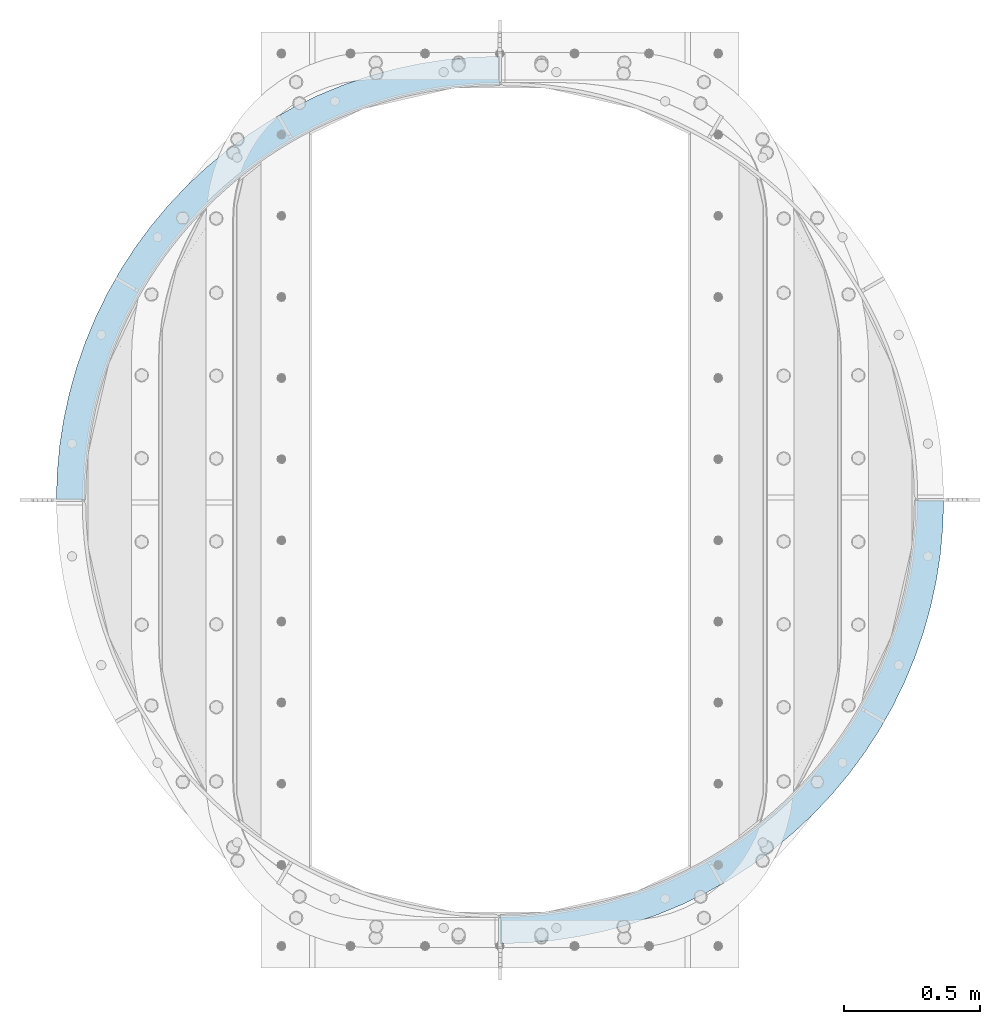
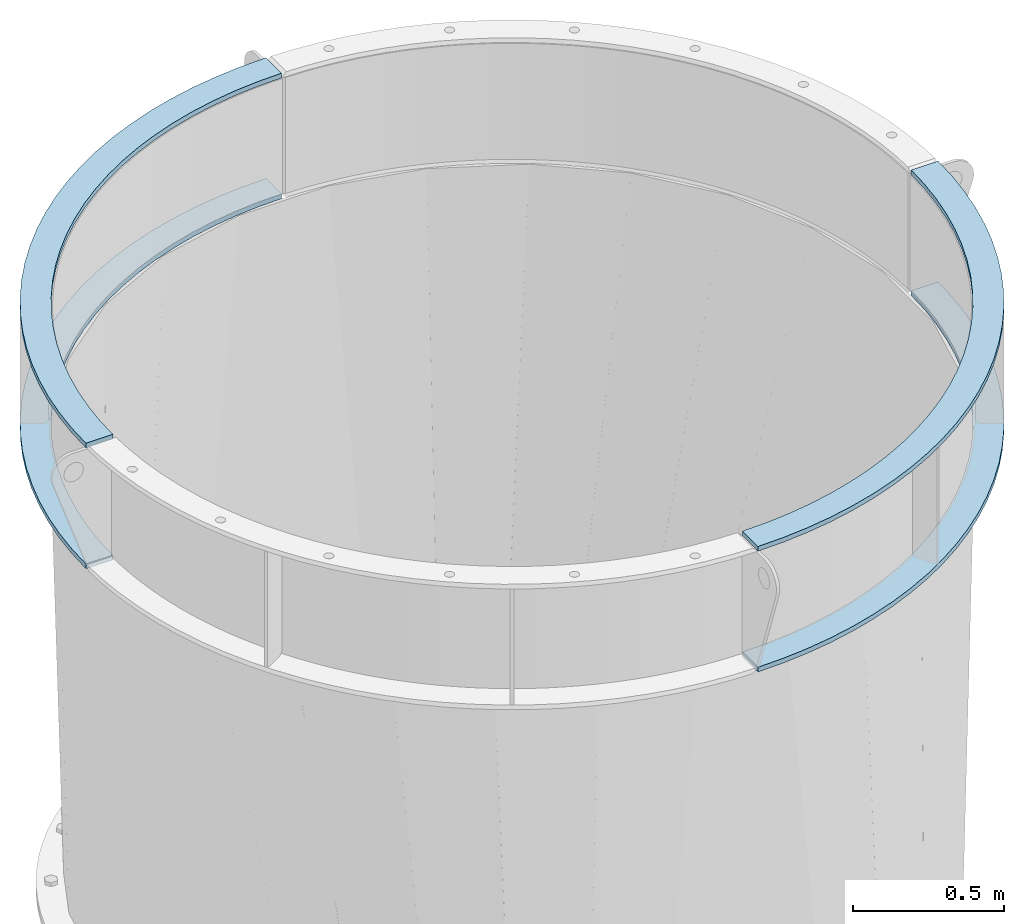
# One storey, part 12 of 15: 4 plates, 1 element without a shape of its own.
"""IFC2X3 building model written with IfcOpenShell, lengths in millimetres."""

from ifc_helpers import new_model, si_unit, frame, origin_with_axes, place, context, subcontext, project, spatial, faceted_brep, material, type_object, element, aggregate, save


model = new_model("IFC2X3")

# Units and contexts
model_context = context("Model", 3, precision=1e-05, world=origin_with_axes())
body_context = subcontext(model_context, "Body", "Model", "MODEL_VIEW")
ifc_project = project(units=[si_unit("LENGTHUNIT", "METRE", prefix="MILLI"), si_unit("AREAUNIT", "SQUARE_METRE"), si_unit("VOLUMEUNIT", "CUBIC_METRE"), si_unit("MASSUNIT", "GRAM", prefix="KILO"), si_unit("TIMEUNIT", "SECOND"), si_unit("PLANEANGLEUNIT", "RADIAN"), si_unit("SOLIDANGLEUNIT", "STERADIAN"), si_unit("THERMODYNAMICTEMPERATUREUNIT", "DEGREE_CELSIUS"), si_unit("LUMINOUSINTENSITYUNIT", "LUMEN")], contexts=[model_context])

# Site, building, storey
site_placement = place(None, origin_with_axes())
site = spatial("IfcSite", under=ifc_project, at=site_placement, CompositionType="ELEMENT")
building_placement = place(site_placement, origin_with_axes())
building = spatial("IfcBuilding", under=site, at=building_placement, Name="Undefined", CompositionType="ELEMENT")
storey_placement = place(building_placement, origin_with_axes())
storey = spatial("IfcBuildingStorey", under=building, at=storey_placement, Name="Undefined", CompositionType="ELEMENT", Elevation=0.0)

# Assembly, plates
assembly_placement = place(storey_placement, origin_with_axes())
assembly = element("IfcElementAssembly", 1, at=assembly_placement, inside=storey, Name="TRANSITION", AssemblyPlace="NOTDEFINED", PredefinedType="RIGID_FRAME")
ifc_material = material(Name="STEEL/A36")
plate_type = type_object("IfcPlateType", PredefinedType="NOTDEFINED")
plate_1_placement = place(assembly_placement, frame((-752.474951171874, 1720.85000000027, 6762.755), z_axis=(0.0, 1.0, 0.0), x_axis=(1.0, 0.0, 0.0)))
plate_1 = element("IfcPlate", 2, at=plate_1_placement, type_object=plate_type, material=ifc_material, Name="PLATE", context=body_context, shape_type="Brep", body=[
    faceted_brep([(0.0, -9.52499999999964, 0.0), (2.97740452312382, -9.52499999999964, 98.5346858164392), (2.97740452312382, 9.52499999999964, 98.5346858164392), (0.0, 9.52499999999964, 0.0), (11.8987531805783, -9.52499999999964, 196.709829232645), (11.8987531805783, 9.52499999999964, 196.709829232645), (26.7314929387344, -9.52499999999964, 294.167199800127), (26.7314929387344, 9.52499999999964, 294.167199800127), (47.4215007392556, -9.52499999999964, 390.55118614576), (47.4215007392556, 9.52499999999964, 390.55118614576), (73.8932809881087, -9.52499999999964, 485.510093559006), (73.8932809881087, 9.52499999999964, 485.510093559006), (106.050241030797, -9.52499999999964, 578.697427287759), (106.050241030797, 9.52499999999964, 578.697427287759), (143.77504360848, -9.52499999999964, 669.77315686011), (143.77504360848, 9.52499999999964, 669.77315686011), (186.930035008899, -9.52499999999964, 758.404956818652), (186.930035008899, 9.52499999999964, 758.404956818652), (235.357747349844, -9.52499999999964, 844.269419340023), (235.357747349844, 9.52499999999964, 844.269419340023), (288.881473162371, -9.52499999999964, 927.053234314973), (288.881473162371, 9.52499999999964, 927.053234314973), (347.30591017719, -9.52499999999964, 1006.45433258296), (347.30591017719, 9.52499999999964, 1006.45433258296), (410.417873961457, -9.52499999999964, 1082.18298814976), (410.417873961457, 9.52499999999964, 1082.18298814976), (477.987075805645, -9.52499999999964, 1153.96287536617), (477.987075805645, 9.52499999999964, 1153.96287536617), (549.766963022063, -9.52499999999964, 1221.53207721036), (549.766963022063, 9.52499999999964, 1221.53207721036), (625.495618588867, -9.52499999999964, 1284.64404099462), (625.495618588867, 9.52499999999964, 1284.64404099462), (704.896716856861, -9.52499999999964, 1343.06847800943), (704.896716856861, 9.52499999999964, 1343.06847800943), (787.680531831816, -9.52499999999964, 1396.59220382195), (787.680531831816, 9.52499999999964, 1396.59220382195), (873.544994353191, -9.52499999999964, 1445.01991616288), (873.544994353191, 9.52499999999964, 1445.01991616288), (962.176794311736, -9.52499999999964, 1488.1749075633), (962.176794311736, 9.52499999999964, 1488.1749075633), (1053.25252388409, -9.52499999999964, 1525.89971014097), (1053.25252388409, 9.52499999999964, 1525.89971014097), (1146.43985761284, -9.52499999999964, 1558.05667018365), (1146.43985761284, 9.52499999999964, 1558.05667018365), (1241.39876502609, -9.52499999999964, 1584.52845043249), (1241.39876502609, 9.52499999999964, 1584.52845043249), (1337.78275137173, -9.52499999999964, 1605.21845823301), (1337.78275137173, 9.52499999999964, 1605.21845823301), (1435.24012193921, -9.52499999999964, 1620.05119799115), (1435.24012193921, 9.52499999999964, 1620.05119799115), (1533.41526535541, -9.52499999999964, 1628.9725466486), (1533.41526535541, 9.52499999999964, 1628.9725466486), (1631.94995117188, -9.52499999999964, 1631.94995117188), (1631.94995117188, 9.52499999999964, 1631.94995117188), (1631.94995117188, -9.52499999999964, 1528.76245117188), (1631.94995117188, 9.52499999999964, 1528.76245117188), (1539.64557176765, -9.52499999999964, 1525.97330598564), (1539.64557176765, 9.52499999999964, 1525.97330598564), (1447.67800108681, -9.52499999999964, 1517.61604978902), (1447.67800108681, 9.52499999999964, 1517.61604978902), (1356.3828188116, -9.52499999999964, 1503.7211773028), (1356.3828188116, 9.52499999999964, 1503.7211773028), (1266.09315115196, -9.52499999999964, 1484.33938940837), (1266.09315115196, 9.52499999999964, 1484.33938940837), (1177.13845530415, -9.52499999999964, 1459.54140814586), (1177.13845530415, 9.52499999999964, 1459.54140814586), (1089.84331729719, -9.52499999999964, 1429.41771865703), (1089.84331729719, 9.52499999999964, 1429.41771865703), (1004.5262676137, -9.52499999999964, 1394.07823901488), (1004.5262676137, 9.52499999999964, 1394.07823901488), (921.498618906718, -9.52499999999964, 1353.65191914449), (921.498618906718, 9.52499999999964, 1353.65191914449), (841.063330053642, -9.52499999999964, 1308.28627029875), (841.063330053642, 9.52499999999964, 1308.28627029875), (763.513900692163, -9.52499999999964, 1258.1468268058), (763.513900692163, 9.52499999999964, 1258.1468268058), (689.133300271954, -9.52499999999964, 1203.41654205227), (689.133300271954, 9.52499999999964, 1203.41654205227), (618.192935529858, -9.52499999999964, 1144.29512090619), (618.192935529858, 9.52499999999964, 1144.29512090619), (550.95166015617, -9.52499999999964, 1080.99829101564), (550.95166015617, 9.52499999999964, 1080.99829101564), (487.654830265622, -9.52499999999964, 1013.75701564195), (487.654830265622, 9.52499999999964, 1013.75701564195), (428.533409119548, -9.52499999999964, 942.816650899848), (428.533409119548, 9.52499999999964, 942.816650899848), (373.80312436602, -9.52499999999964, 868.436050479634), (373.80312436602, 9.52499999999964, 868.436050479634), (323.663680873077, -9.52499999999964, 790.88662111815), (323.663680873077, 9.52499999999964, 790.88662111815), (278.298032027336, -9.52499999999964, 710.451332265068), (278.298032027336, 9.52499999999964, 710.451332265068), (237.871712156949, -9.52499999999964, 627.423683558081), (237.871712156949, 9.52499999999964, 627.423683558081), (202.532232514805, -9.52499999999964, 542.106633874585), (202.532232514805, 9.52499999999964, 542.106633874585), (172.408543025982, -9.52499999999964, 454.811495867622), (172.408543025982, 9.52499999999964, 454.811495867622), (147.610561763468, -9.52499999999964, 365.856800019807), (147.610561763468, 9.52499999999964, 365.856800019807), (128.228773869042, -9.52499999999964, 275.567132360162), (128.228773869042, 9.52499999999964, 275.567132360162), (114.333901382821, -9.52499999999964, 184.271950084946), (114.333901382821, 9.52499999999964, 184.271950084946), (105.976645186203, -9.52499999999964, 92.3043794040959), (105.976645186203, 9.52499999999964, 92.3043794040959), (103.1875, -9.52499999999964, 0.0), (103.1875, 9.52499999999964, 0.0)], [[[0, 1, 2, 3]], [[1, 4, 5, 2]], [[4, 6, 7, 5]], [[6, 8, 9, 7]], [[8, 10, 11, 9]], [[10, 12, 13, 11]], [[12, 14, 15, 13]], [[14, 16, 17, 15]], [[16, 18, 19, 17]], [[18, 20, 21, 19]], [[20, 22, 23, 21]], [[22, 24, 25, 23]], [[24, 26, 27, 25]], [[26, 28, 29, 27]], [[28, 30, 31, 29]], [[30, 32, 33, 31]], [[32, 34, 35, 33]], [[34, 36, 37, 35]], [[36, 38, 39, 37]], [[38, 40, 41, 39]], [[40, 42, 43, 41]], [[42, 44, 45, 43]], [[44, 46, 47, 45]], [[46, 48, 49, 47]], [[48, 50, 51, 49]], [[50, 52, 53, 51]], [[52, 54, 55, 53]], [[54, 56, 57, 55]], [[56, 58, 59, 57]], [[58, 60, 61, 59]], [[60, 62, 63, 61]], [[62, 64, 65, 63]], [[64, 66, 67, 65]], [[66, 68, 69, 67]], [[68, 70, 71, 69]], [[70, 72, 73, 71]], [[72, 74, 75, 73]], [[74, 76, 77, 75]], [[76, 78, 79, 77]], [[78, 80, 81, 79]], [[80, 82, 83, 81]], [[82, 84, 85, 83]], [[84, 86, 87, 85]], [[86, 88, 89, 87]], [[88, 90, 91, 89]], [[90, 92, 93, 91]], [[92, 94, 95, 93]], [[94, 96, 97, 95]], [[96, 98, 99, 97]], [[98, 100, 101, 99]], [[100, 102, 103, 101]], [[102, 104, 105, 103]], [[104, 106, 107, 105]], [[106, 0, 3, 107]], [[5, 7, 9, 11, 13, 15, 17, 19, 21, 23, 25, 27, 29, 31, 33, 35, 37, 39, 41, 43, 45, 47, 49, 51, 53, 55, 57, 59, 61, 63, 65, 67, 69, 71, 73, 75, 77, 79, 81, 83, 85, 87, 89, 91, 93, 95, 97, 99, 101, 103, 105, 107, 3, 2]], [[106, 104, 102, 100, 98, 96, 94, 92, 90, 88, 86, 84, 82, 80, 78, 76, 74, 72, 70, 68, 66, 64, 62, 60, 58, 56, 54, 52, 50, 48, 46, 44, 42, 40, 38, 36, 34, 32, 30, 28, 26, 24, 22, 20, 18, 16, 14, 12, 10, 8, 6, 4, 1, 0]]]),
])
plate_2_placement = place(assembly_placement, frame((-752.474999999779, 1720.85000000027, 6273.805), z_axis=(0.0, 1.0, 0.0), x_axis=(1.0, 0.0, 0.0)))
plate_2 = element("IfcPlate", 3, at=plate_2_placement, type_object=plate_type, material=ifc_material, Name="PLATE", context=body_context, shape_type="Brep", body=[
    faceted_brep([(0.0, -9.52499999999964, 0.0), (2.97740452312382, -9.52499999999964, 98.5346858164392), (2.97740452312382, 9.52499999999964, 98.5346858164392), (0.0, 9.52499999999964, 0.0), (11.8987531805783, -9.52499999999964, 196.709829232645), (11.8987531805783, 9.52499999999964, 196.709829232645), (26.7314929387344, -9.52499999999964, 294.167199800127), (26.7314929387344, 9.52499999999964, 294.167199800127), (47.4215007392556, -9.52499999999964, 390.55118614576), (47.4215007392556, 9.52499999999964, 390.55118614576), (73.8932809881087, -9.52499999999964, 485.510093559006), (73.8932809881087, 9.52499999999964, 485.510093559006), (106.050241030797, -9.52499999999964, 578.697427287759), (106.050241030797, 9.52499999999964, 578.697427287759), (143.77504360848, -9.52499999999964, 669.77315686011), (143.77504360848, 9.52499999999964, 669.77315686011), (186.930035008899, -9.52499999999964, 758.404956818652), (186.930035008899, 9.52499999999964, 758.404956818652), (235.357747349844, -9.52499999999964, 844.269419340023), (235.357747349844, 9.52499999999964, 844.269419340023), (288.881473162371, -9.52499999999964, 927.053234314973), (288.881473162371, 9.52499999999964, 927.053234314973), (347.30591017719, -9.52499999999964, 1006.45433258296), (347.30591017719, 9.52499999999964, 1006.45433258296), (410.417873961457, -9.52499999999964, 1082.18298814976), (410.417873961457, 9.52499999999964, 1082.18298814976), (477.987075805645, -9.52499999999964, 1153.96287536617), (477.987075805645, 9.52499999999964, 1153.96287536617), (549.766963022063, -9.52499999999964, 1221.53207721036), (549.766963022063, 9.52499999999964, 1221.53207721036), (625.495618588867, -9.52499999999964, 1284.64404099462), (625.495618588867, 9.52499999999964, 1284.64404099462), (704.896716856861, -9.52499999999964, 1343.06847800943), (704.896716856861, 9.52499999999964, 1343.06847800943), (787.680531831816, -9.52499999999964, 1396.59220382195), (787.680531831816, 9.52499999999964, 1396.59220382195), (873.544994353191, -9.52499999999964, 1445.01991616288), (873.544994353191, 9.52499999999964, 1445.01991616288), (962.176794311736, -9.52499999999964, 1488.1749075633), (962.176794311736, 9.52499999999964, 1488.1749075633), (1053.25252388409, -9.52499999999964, 1525.89971014097), (1053.25252388409, 9.52499999999964, 1525.89971014097), (1146.43985761284, -9.52499999999964, 1558.05667018365), (1146.43985761284, 9.52499999999964, 1558.05667018365), (1241.39876502609, -9.52499999999964, 1584.52845043249), (1241.39876502609, 9.52499999999964, 1584.52845043249), (1337.78275137173, -9.52499999999964, 1605.21845823301), (1337.78275137173, 9.52499999999964, 1605.21845823301), (1435.24012193921, -9.52499999999964, 1620.05119799115), (1435.24012193921, 9.52499999999964, 1620.05119799115), (1533.41526535541, -9.52499999999964, 1628.9725466486), (1533.41526535541, 9.52499999999964, 1628.9725466486), (1631.94995117188, -9.52499999999964, 1631.94995117188), (1631.94995117188, 9.52499999999964, 1631.94995117188), (1631.94995117188, -9.52499999999964, 1528.76245117188), (1631.94995117188, 9.52499999999964, 1528.76245117188), (1539.64557176765, -9.52499999999964, 1525.97330598564), (1539.64557176765, 9.52499999999964, 1525.97330598564), (1447.67800108681, -9.52499999999964, 1517.61604978902), (1447.67800108681, 9.52499999999964, 1517.61604978902), (1356.3828188116, -9.52499999999964, 1503.7211773028), (1356.3828188116, 9.52499999999964, 1503.7211773028), (1266.09315115196, -9.52499999999964, 1484.33938940837), (1266.09315115196, 9.52499999999964, 1484.33938940837), (1177.13845530415, -9.52499999999964, 1459.54140814586), (1177.13845530415, 9.52499999999964, 1459.54140814586), (1089.84331729719, -9.52499999999964, 1429.41771865703), (1089.84331729719, 9.52499999999964, 1429.41771865703), (1004.5262676137, -9.52499999999964, 1394.07823901488), (1004.5262676137, 9.52499999999964, 1394.07823901488), (921.498618906718, -9.52499999999964, 1353.65191914449), (921.498618906718, 9.52499999999964, 1353.65191914449), (841.063330053642, -9.52499999999964, 1308.28627029875), (841.063330053642, 9.52499999999964, 1308.28627029875), (763.513900692163, -9.52499999999964, 1258.1468268058), (763.513900692163, 9.52499999999964, 1258.1468268058), (689.133300271954, -9.52499999999964, 1203.41654205227), (689.133300271954, 9.52499999999964, 1203.41654205227), (618.192935529858, -9.52499999999964, 1144.29512090619), (618.192935529858, 9.52499999999964, 1144.29512090619), (550.95166015617, -9.52499999999964, 1080.99829101564), (550.95166015617, 9.52499999999964, 1080.99829101564), (487.654830265622, -9.52499999999964, 1013.75701564195), (487.654830265622, 9.52499999999964, 1013.75701564195), (428.533409119548, -9.52499999999964, 942.816650899848), (428.533409119548, 9.52499999999964, 942.816650899848), (373.80312436602, -9.52499999999964, 868.436050479634), (373.80312436602, 9.52499999999964, 868.436050479634), (323.663680873077, -9.52499999999964, 790.88662111815), (323.663680873077, 9.52499999999964, 790.88662111815), (278.298032027336, -9.52499999999964, 710.451332265068), (278.298032027336, 9.52499999999964, 710.451332265068), (237.871712156949, -9.52499999999964, 627.423683558081), (237.871712156949, 9.52499999999964, 627.423683558081), (202.532232514805, -9.52499999999964, 542.106633874585), (202.532232514805, 9.52499999999964, 542.106633874585), (172.408543025982, -9.52499999999964, 454.811495867622), (172.408543025982, 9.52499999999964, 454.811495867622), (147.610561763468, -9.52499999999964, 365.856800019807), (147.610561763468, 9.52499999999964, 365.856800019807), (128.228773869042, -9.52499999999964, 275.567132360162), (128.228773869042, 9.52499999999964, 275.567132360162), (114.333901382821, -9.52499999999964, 184.271950084946), (114.333901382821, 9.52499999999964, 184.271950084946), (105.976645186203, -9.52499999999964, 92.3043794040959), (105.976645186203, 9.52499999999964, 92.3043794040959), (103.1875, -9.52499999999964, 0.0), (103.1875, 9.52499999999964, 0.0)], [[[0, 1, 2, 3]], [[1, 4, 5, 2]], [[4, 6, 7, 5]], [[6, 8, 9, 7]], [[8, 10, 11, 9]], [[10, 12, 13, 11]], [[12, 14, 15, 13]], [[14, 16, 17, 15]], [[16, 18, 19, 17]], [[18, 20, 21, 19]], [[20, 22, 23, 21]], [[22, 24, 25, 23]], [[24, 26, 27, 25]], [[26, 28, 29, 27]], [[28, 30, 31, 29]], [[30, 32, 33, 31]], [[32, 34, 35, 33]], [[34, 36, 37, 35]], [[36, 38, 39, 37]], [[38, 40, 41, 39]], [[40, 42, 43, 41]], [[42, 44, 45, 43]], [[44, 46, 47, 45]], [[46, 48, 49, 47]], [[48, 50, 51, 49]], [[50, 52, 53, 51]], [[52, 54, 55, 53]], [[54, 56, 57, 55]], [[56, 58, 59, 57]], [[58, 60, 61, 59]], [[60, 62, 63, 61]], [[62, 64, 65, 63]], [[64, 66, 67, 65]], [[66, 68, 69, 67]], [[68, 70, 71, 69]], [[70, 72, 73, 71]], [[72, 74, 75, 73]], [[74, 76, 77, 75]], [[76, 78, 79, 77]], [[78, 80, 81, 79]], [[80, 82, 83, 81]], [[82, 84, 85, 83]], [[84, 86, 87, 85]], [[86, 88, 89, 87]], [[88, 90, 91, 89]], [[90, 92, 93, 91]], [[92, 94, 95, 93]], [[94, 96, 97, 95]], [[96, 98, 99, 97]], [[98, 100, 101, 99]], [[100, 102, 103, 101]], [[102, 104, 105, 103]], [[104, 106, 107, 105]], [[106, 0, 3, 107]], [[5, 7, 9, 11, 13, 15, 17, 19, 21, 23, 25, 27, 29, 31, 33, 35, 37, 39, 41, 43, 45, 47, 49, 51, 53, 55, 57, 59, 61, 63, 65, 67, 69, 71, 73, 75, 77, 79, 81, 83, 85, 87, 89, 91, 93, 95, 97, 99, 101, 103, 105, 107, 3, 2]], [[106, 104, 102, 100, 98, 96, 94, 92, 90, 88, 86, 84, 82, 80, 78, 76, 74, 72, 70, 68, 66, 64, 62, 60, 58, 56, 54, 52, 50, 48, 46, 44, 42, 40, 38, 36, 34, 32, 30, 28, 26, 24, 22, 20, 18, 16, 14, 12, 10, 8, 6, 4, 1, 0]]]),
])
plate_3_placement = place(assembly_placement, frame((2511.42495117187, 1720.84999999973, 6762.755), z_axis=(0.0, -1.0, 0.0), x_axis=(-1.0, 0.0, 0.0)))
plate_3 = element("IfcPlate", 4, at=plate_3_placement, type_object=plate_type, material=ifc_material, Name="PLATE", context=body_context, shape_type="Brep", body=[
    faceted_brep([(0.0, -9.52499999999964, 0.0), (2.97740452312382, -9.52499999999964, 98.5346858164392), (2.97740452312382, 9.52499999999964, 98.5346858164392), (0.0, 9.52499999999964, 0.0), (11.8987531805783, -9.52499999999964, 196.709829232645), (11.8987531805783, 9.52499999999964, 196.709829232645), (26.7314929387344, -9.52499999999964, 294.167199800127), (26.7314929387344, 9.52499999999964, 294.167199800127), (47.4215007392556, -9.52499999999964, 390.55118614576), (47.4215007392556, 9.52499999999964, 390.55118614576), (73.8932809881087, -9.52499999999964, 485.510093559006), (73.8932809881087, 9.52499999999964, 485.510093559006), (106.050241030797, -9.52499999999964, 578.697427287759), (106.050241030797, 9.52499999999964, 578.697427287759), (143.77504360848, -9.52499999999964, 669.77315686011), (143.77504360848, 9.52499999999964, 669.77315686011), (186.930035008899, -9.52499999999964, 758.404956818652), (186.930035008899, 9.52499999999964, 758.404956818652), (235.357747349844, -9.52499999999964, 844.269419340023), (235.357747349844, 9.52499999999964, 844.269419340023), (288.881473162371, -9.52499999999964, 927.053234314973), (288.881473162371, 9.52499999999964, 927.053234314973), (347.30591017719, -9.52499999999964, 1006.45433258296), (347.30591017719, 9.52499999999964, 1006.45433258296), (410.417873961457, -9.52499999999964, 1082.18298814976), (410.417873961457, 9.52499999999964, 1082.18298814976), (477.987075805645, -9.52499999999964, 1153.96287536617), (477.987075805645, 9.52499999999964, 1153.96287536617), (549.766963022063, -9.52499999999964, 1221.53207721036), (549.766963022063, 9.52499999999964, 1221.53207721036), (625.495618588867, -9.52499999999964, 1284.64404099462), (625.495618588867, 9.52499999999964, 1284.64404099462), (704.896716856861, -9.52499999999964, 1343.06847800943), (704.896716856861, 9.52499999999964, 1343.06847800943), (787.680531831816, -9.52499999999964, 1396.59220382195), (787.680531831816, 9.52499999999964, 1396.59220382195), (873.544994353191, -9.52499999999964, 1445.01991616288), (873.544994353191, 9.52499999999964, 1445.01991616288), (962.176794311736, -9.52499999999964, 1488.1749075633), (962.176794311736, 9.52499999999964, 1488.1749075633), (1053.25252388409, -9.52499999999964, 1525.89971014097), (1053.25252388409, 9.52499999999964, 1525.89971014097), (1146.43985761284, -9.52499999999964, 1558.05667018365), (1146.43985761284, 9.52499999999964, 1558.05667018365), (1241.39876502609, -9.52499999999964, 1584.52845043249), (1241.39876502609, 9.52499999999964, 1584.52845043249), (1337.78275137173, -9.52499999999964, 1605.21845823301), (1337.78275137173, 9.52499999999964, 1605.21845823301), (1435.24012193921, -9.52499999999964, 1620.05119799115), (1435.24012193921, 9.52499999999964, 1620.05119799115), (1533.41526535541, -9.52499999999964, 1628.9725466486), (1533.41526535541, 9.52499999999964, 1628.9725466486), (1631.94995117188, -9.52499999999964, 1631.94995117188), (1631.94995117188, 9.52499999999964, 1631.94995117188), (1631.94995117188, -9.52499999999964, 1528.76245117188), (1631.94995117188, 9.52499999999964, 1528.76245117188), (1539.64557176765, -9.52499999999964, 1525.97330598564), (1539.64557176765, 9.52499999999964, 1525.97330598564), (1447.67800108681, -9.52499999999964, 1517.61604978902), (1447.67800108681, 9.52499999999964, 1517.61604978902), (1356.3828188116, -9.52499999999964, 1503.7211773028), (1356.3828188116, 9.52499999999964, 1503.7211773028), (1266.09315115196, -9.52499999999964, 1484.33938940837), (1266.09315115196, 9.52499999999964, 1484.33938940837), (1177.13845530415, -9.52499999999964, 1459.54140814586), (1177.13845530415, 9.52499999999964, 1459.54140814586), (1089.84331729719, -9.52499999999964, 1429.41771865703), (1089.84331729719, 9.52499999999964, 1429.41771865703), (1004.5262676137, -9.52499999999964, 1394.07823901488), (1004.5262676137, 9.52499999999964, 1394.07823901488), (921.498618906718, -9.52499999999964, 1353.65191914449), (921.498618906718, 9.52499999999964, 1353.65191914449), (841.063330053642, -9.52499999999964, 1308.28627029875), (841.063330053642, 9.52499999999964, 1308.28627029875), (763.513900692163, -9.52499999999964, 1258.1468268058), (763.513900692163, 9.52499999999964, 1258.1468268058), (689.133300271954, -9.52499999999964, 1203.41654205227), (689.133300271954, 9.52499999999964, 1203.41654205227), (618.192935529858, -9.52499999999964, 1144.29512090619), (618.192935529858, 9.52499999999964, 1144.29512090619), (550.95166015617, -9.52499999999964, 1080.99829101564), (550.95166015617, 9.52499999999964, 1080.99829101564), (487.654830265622, -9.52499999999964, 1013.75701564195), (487.654830265622, 9.52499999999964, 1013.75701564195), (428.533409119548, -9.52499999999964, 942.816650899848), (428.533409119548, 9.52499999999964, 942.816650899848), (373.80312436602, -9.52499999999964, 868.436050479634), (373.80312436602, 9.52499999999964, 868.436050479634), (323.663680873077, -9.52499999999964, 790.88662111815), (323.663680873077, 9.52499999999964, 790.88662111815), (278.298032027336, -9.52499999999964, 710.451332265068), (278.298032027336, 9.52499999999964, 710.451332265068), (237.871712156949, -9.52499999999964, 627.423683558081), (237.871712156949, 9.52499999999964, 627.423683558081), (202.532232514805, -9.52499999999964, 542.106633874585), (202.532232514805, 9.52499999999964, 542.106633874585), (172.408543025982, -9.52499999999964, 454.811495867622), (172.408543025982, 9.52499999999964, 454.811495867622), (147.610561763468, -9.52499999999964, 365.856800019807), (147.610561763468, 9.52499999999964, 365.856800019807), (128.228773869042, -9.52499999999964, 275.567132360162), (128.228773869042, 9.52499999999964, 275.567132360162), (114.333901382821, -9.52499999999964, 184.271950084946), (114.333901382821, 9.52499999999964, 184.271950084946), (105.976645186203, -9.52499999999964, 92.3043794040959), (105.976645186203, 9.52499999999964, 92.3043794040959), (103.1875, -9.52499999999964, 0.0), (103.1875, 9.52499999999964, 0.0)], [[[0, 1, 2, 3]], [[1, 4, 5, 2]], [[4, 6, 7, 5]], [[6, 8, 9, 7]], [[8, 10, 11, 9]], [[10, 12, 13, 11]], [[12, 14, 15, 13]], [[14, 16, 17, 15]], [[16, 18, 19, 17]], [[18, 20, 21, 19]], [[20, 22, 23, 21]], [[22, 24, 25, 23]], [[24, 26, 27, 25]], [[26, 28, 29, 27]], [[28, 30, 31, 29]], [[30, 32, 33, 31]], [[32, 34, 35, 33]], [[34, 36, 37, 35]], [[36, 38, 39, 37]], [[38, 40, 41, 39]], [[40, 42, 43, 41]], [[42, 44, 45, 43]], [[44, 46, 47, 45]], [[46, 48, 49, 47]], [[48, 50, 51, 49]], [[50, 52, 53, 51]], [[52, 54, 55, 53]], [[54, 56, 57, 55]], [[56, 58, 59, 57]], [[58, 60, 61, 59]], [[60, 62, 63, 61]], [[62, 64, 65, 63]], [[64, 66, 67, 65]], [[66, 68, 69, 67]], [[68, 70, 71, 69]], [[70, 72, 73, 71]], [[72, 74, 75, 73]], [[74, 76, 77, 75]], [[76, 78, 79, 77]], [[78, 80, 81, 79]], [[80, 82, 83, 81]], [[82, 84, 85, 83]], [[84, 86, 87, 85]], [[86, 88, 89, 87]], [[88, 90, 91, 89]], [[90, 92, 93, 91]], [[92, 94, 95, 93]], [[94, 96, 97, 95]], [[96, 98, 99, 97]], [[98, 100, 101, 99]], [[100, 102, 103, 101]], [[102, 104, 105, 103]], [[104, 106, 107, 105]], [[106, 0, 3, 107]], [[5, 7, 9, 11, 13, 15, 17, 19, 21, 23, 25, 27, 29, 31, 33, 35, 37, 39, 41, 43, 45, 47, 49, 51, 53, 55, 57, 59, 61, 63, 65, 67, 69, 71, 73, 75, 77, 79, 81, 83, 85, 87, 89, 91, 93, 95, 97, 99, 101, 103, 105, 107, 3, 2]], [[106, 104, 102, 100, 98, 96, 94, 92, 90, 88, 86, 84, 82, 80, 78, 76, 74, 72, 70, 68, 66, 64, 62, 60, 58, 56, 54, 52, 50, 48, 46, 44, 42, 40, 38, 36, 34, 32, 30, 28, 26, 24, 22, 20, 18, 16, 14, 12, 10, 8, 6, 4, 1, 0]]]),
])
plate_4_placement = place(assembly_placement, frame((2511.42499999978, 1720.84999999973, 6273.805), z_axis=(0.0, -1.0, 0.0), x_axis=(-1.0, 0.0, 0.0)))
plate_4 = element("IfcPlate", 5, at=plate_4_placement, type_object=plate_type, material=ifc_material, Name="PLATE", context=body_context, shape_type="Brep", body=[
    faceted_brep([(0.0, -9.52499999999964, 0.0), (2.97740452312382, -9.52499999999964, 98.5346858164392), (2.97740452312382, 9.52499999999964, 98.5346858164392), (0.0, 9.52499999999964, 0.0), (11.8987531805783, -9.52499999999964, 196.709829232645), (11.8987531805783, 9.52499999999964, 196.709829232645), (26.7314929387344, -9.52499999999964, 294.167199800127), (26.7314929387344, 9.52499999999964, 294.167199800127), (47.4215007392556, -9.52499999999964, 390.55118614576), (47.4215007392556, 9.52499999999964, 390.55118614576), (73.8932809881087, -9.52499999999964, 485.510093559006), (73.8932809881087, 9.52499999999964, 485.510093559006), (106.050241030797, -9.52499999999964, 578.697427287759), (106.050241030797, 9.52499999999964, 578.697427287759), (143.77504360848, -9.52499999999964, 669.77315686011), (143.77504360848, 9.52499999999964, 669.77315686011), (186.930035008899, -9.52499999999964, 758.404956818652), (186.930035008899, 9.52499999999964, 758.404956818652), (235.357747349844, -9.52499999999964, 844.269419340023), (235.357747349844, 9.52499999999964, 844.269419340023), (288.881473162371, -9.52499999999964, 927.053234314973), (288.881473162371, 9.52499999999964, 927.053234314973), (347.30591017719, -9.52499999999964, 1006.45433258296), (347.30591017719, 9.52499999999964, 1006.45433258296), (410.417873961457, -9.52499999999964, 1082.18298814976), (410.417873961457, 9.52499999999964, 1082.18298814976), (477.987075805645, -9.52499999999964, 1153.96287536617), (477.987075805645, 9.52499999999964, 1153.96287536617), (549.766963022063, -9.52499999999964, 1221.53207721036), (549.766963022063, 9.52499999999964, 1221.53207721036), (625.495618588867, -9.52499999999964, 1284.64404099462), (625.495618588867, 9.52499999999964, 1284.64404099462), (704.896716856861, -9.52499999999964, 1343.06847800943), (704.896716856861, 9.52499999999964, 1343.06847800943), (787.680531831816, -9.52499999999964, 1396.59220382195), (787.680531831816, 9.52499999999964, 1396.59220382195), (873.544994353191, -9.52499999999964, 1445.01991616288), (873.544994353191, 9.52499999999964, 1445.01991616288), (962.176794311736, -9.52499999999964, 1488.1749075633), (962.176794311736, 9.52499999999964, 1488.1749075633), (1053.25252388409, -9.52499999999964, 1525.89971014097), (1053.25252388409, 9.52499999999964, 1525.89971014097), (1146.43985761284, -9.52499999999964, 1558.05667018365), (1146.43985761284, 9.52499999999964, 1558.05667018365), (1241.39876502609, -9.52499999999964, 1584.52845043249), (1241.39876502609, 9.52499999999964, 1584.52845043249), (1337.78275137173, -9.52499999999964, 1605.21845823301), (1337.78275137173, 9.52499999999964, 1605.21845823301), (1435.24012193921, -9.52499999999964, 1620.05119799115), (1435.24012193921, 9.52499999999964, 1620.05119799115), (1533.41526535541, -9.52499999999964, 1628.9725466486), (1533.41526535541, 9.52499999999964, 1628.9725466486), (1631.94995117188, -9.52499999999964, 1631.94995117188), (1631.94995117188, 9.52499999999964, 1631.94995117188), (1631.94995117188, -9.52499999999964, 1528.76245117188), (1631.94995117188, 9.52499999999964, 1528.76245117188), (1539.64557176765, -9.52499999999964, 1525.97330598564), (1539.64557176765, 9.52499999999964, 1525.97330598564), (1447.67800108681, -9.52499999999964, 1517.61604978902), (1447.67800108681, 9.52499999999964, 1517.61604978902), (1356.3828188116, -9.52499999999964, 1503.7211773028), (1356.3828188116, 9.52499999999964, 1503.7211773028), (1266.09315115196, -9.52499999999964, 1484.33938940837), (1266.09315115196, 9.52499999999964, 1484.33938940837), (1177.13845530415, -9.52499999999964, 1459.54140814586), (1177.13845530415, 9.52499999999964, 1459.54140814586), (1089.84331729719, -9.52499999999964, 1429.41771865703), (1089.84331729719, 9.52499999999964, 1429.41771865703), (1004.5262676137, -9.52499999999964, 1394.07823901488), (1004.5262676137, 9.52499999999964, 1394.07823901488), (921.498618906718, -9.52499999999964, 1353.65191914449), (921.498618906718, 9.52499999999964, 1353.65191914449), (841.063330053642, -9.52499999999964, 1308.28627029875), (841.063330053642, 9.52499999999964, 1308.28627029875), (763.513900692163, -9.52499999999964, 1258.1468268058), (763.513900692163, 9.52499999999964, 1258.1468268058), (689.133300271954, -9.52499999999964, 1203.41654205227), (689.133300271954, 9.52499999999964, 1203.41654205227), (618.192935529858, -9.52499999999964, 1144.29512090619), (618.192935529858, 9.52499999999964, 1144.29512090619), (550.95166015617, -9.52499999999964, 1080.99829101564), (550.95166015617, 9.52499999999964, 1080.99829101564), (487.654830265622, -9.52499999999964, 1013.75701564195), (487.654830265622, 9.52499999999964, 1013.75701564195), (428.533409119548, -9.52499999999964, 942.816650899848), (428.533409119548, 9.52499999999964, 942.816650899848), (373.80312436602, -9.52499999999964, 868.436050479634), (373.80312436602, 9.52499999999964, 868.436050479634), (323.663680873077, -9.52499999999964, 790.88662111815), (323.663680873077, 9.52499999999964, 790.88662111815), (278.298032027336, -9.52499999999964, 710.451332265068), (278.298032027336, 9.52499999999964, 710.451332265068), (237.871712156949, -9.52499999999964, 627.423683558081), (237.871712156949, 9.52499999999964, 627.423683558081), (202.532232514805, -9.52499999999964, 542.106633874585), (202.532232514805, 9.52499999999964, 542.106633874585), (172.408543025982, -9.52499999999964, 454.811495867622), (172.408543025982, 9.52499999999964, 454.811495867622), (147.610561763468, -9.52499999999964, 365.856800019807), (147.610561763468, 9.52499999999964, 365.856800019807), (128.228773869042, -9.52499999999964, 275.567132360162), (128.228773869042, 9.52499999999964, 275.567132360162), (114.333901382821, -9.52499999999964, 184.271950084946), (114.333901382821, 9.52499999999964, 184.271950084946), (105.976645186203, -9.52499999999964, 92.3043794040959), (105.976645186203, 9.52499999999964, 92.3043794040959), (103.1875, -9.52499999999964, 0.0), (103.1875, 9.52499999999964, 0.0)], [[[0, 1, 2, 3]], [[1, 4, 5, 2]], [[4, 6, 7, 5]], [[6, 8, 9, 7]], [[8, 10, 11, 9]], [[10, 12, 13, 11]], [[12, 14, 15, 13]], [[14, 16, 17, 15]], [[16, 18, 19, 17]], [[18, 20, 21, 19]], [[20, 22, 23, 21]], [[22, 24, 25, 23]], [[24, 26, 27, 25]], [[26, 28, 29, 27]], [[28, 30, 31, 29]], [[30, 32, 33, 31]], [[32, 34, 35, 33]], [[34, 36, 37, 35]], [[36, 38, 39, 37]], [[38, 40, 41, 39]], [[40, 42, 43, 41]], [[42, 44, 45, 43]], [[44, 46, 47, 45]], [[46, 48, 49, 47]], [[48, 50, 51, 49]], [[50, 52, 53, 51]], [[52, 54, 55, 53]], [[54, 56, 57, 55]], [[56, 58, 59, 57]], [[58, 60, 61, 59]], [[60, 62, 63, 61]], [[62, 64, 65, 63]], [[64, 66, 67, 65]], [[66, 68, 69, 67]], [[68, 70, 71, 69]], [[70, 72, 73, 71]], [[72, 74, 75, 73]], [[74, 76, 77, 75]], [[76, 78, 79, 77]], [[78, 80, 81, 79]], [[80, 82, 83, 81]], [[82, 84, 85, 83]], [[84, 86, 87, 85]], [[86, 88, 89, 87]], [[88, 90, 91, 89]], [[90, 92, 93, 91]], [[92, 94, 95, 93]], [[94, 96, 97, 95]], [[96, 98, 99, 97]], [[98, 100, 101, 99]], [[100, 102, 103, 101]], [[102, 104, 105, 103]], [[104, 106, 107, 105]], [[106, 0, 3, 107]], [[5, 7, 9, 11, 13, 15, 17, 19, 21, 23, 25, 27, 29, 31, 33, 35, 37, 39, 41, 43, 45, 47, 49, 51, 53, 55, 57, 59, 61, 63, 65, 67, 69, 71, 73, 75, 77, 79, 81, 83, 85, 87, 89, 91, 93, 95, 97, 99, 101, 103, 105, 107, 3, 2]], [[106, 104, 102, 100, 98, 96, 94, 92, 90, 88, 86, 84, 82, 80, 78, 76, 74, 72, 70, 68, 66, 64, 62, 60, 58, 56, 54, 52, 50, 48, 46, 44, 42, 40, 38, 36, 34, 32, 30, 28, 26, 24, 22, 20, 18, 16, 14, 12, 10, 8, 6, 4, 1, 0]]]),
])
aggregate(assembly, [plate_1, plate_2, plate_3, plate_4])

save(model, "model.ifc")
